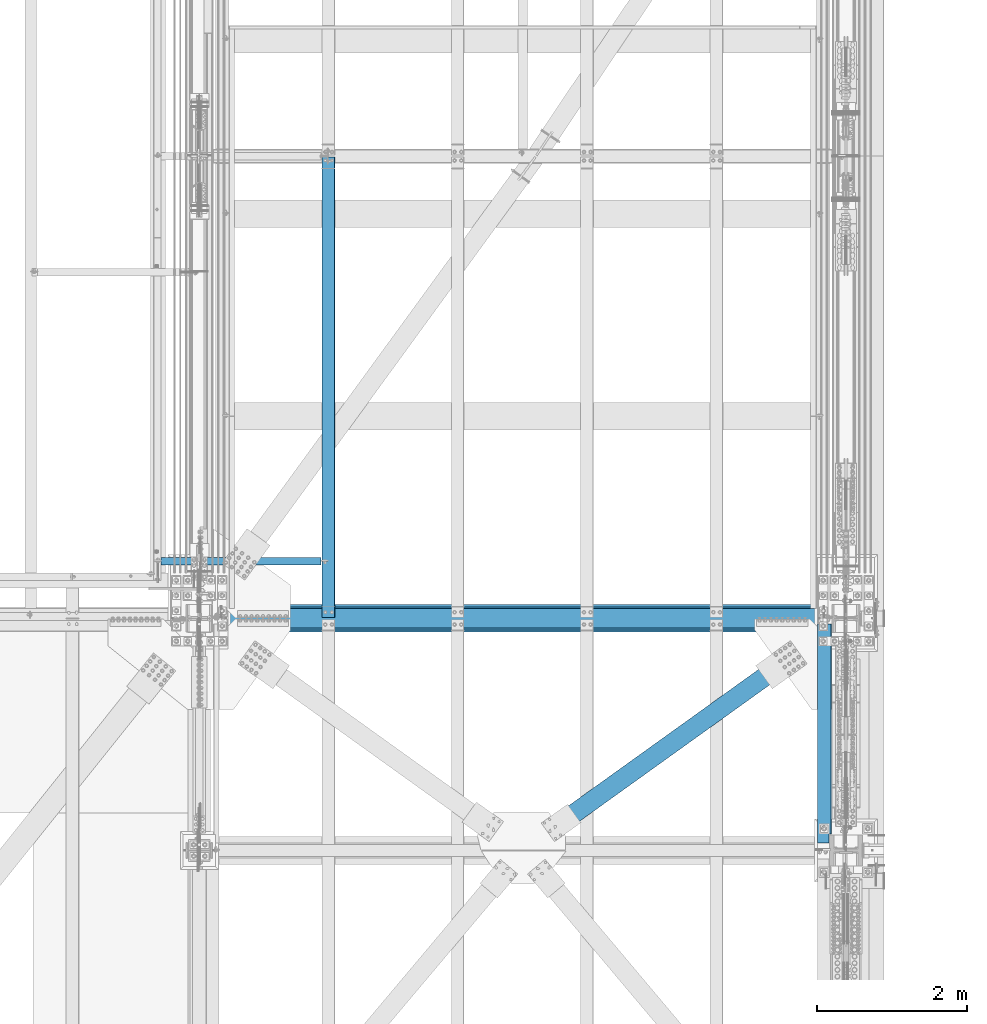
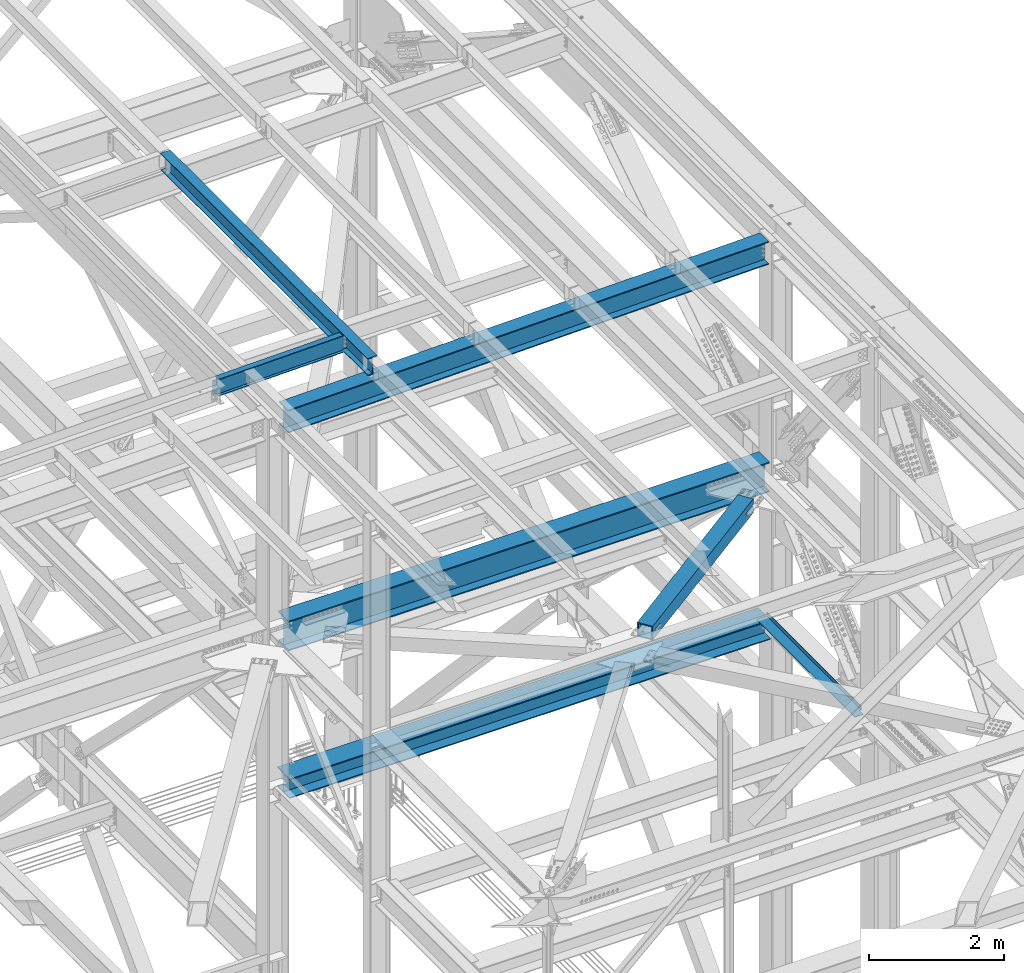
# One storey, part 1988 of 3843: 7 beams, 7 elements without a shape of their own.
"""IFC2X3 building model written with IfcOpenShell, lengths in millimetres."""

import ifcopenshell
import ifcopenshell.guid

model = None  # the IFC model being written
_history = None  # IfcOwnerHistory: only IFC2X3 demands one
_inside = {}  # id of a spatial element -> (the spatial element, [elements in it])
_under = {}  # id of a project, library or spatial element -> (it, [spatial elements below it])
_declared = {}  # id of a project -> (the project, [libraries it declares])
_typed = {}  # id of a type object -> (the type object, [elements of that type])
_made_of = {}  # id of a material, layer set ... -> (it, [elements and type objects made of it])


def new_model(schema):
    """Start an empty IFC model of exactly this schema.

    Asked for "IFC4X3", IfcOpenShell would pick the latest addendum, in which some entities
    have other attributes; the version numbers below select the first issue.
    IFC2X3 requires an IfcOwnerHistory on every rooted entity: one is made here for all.
    """
    global model, _history
    if schema == "IFC4X3":
        model = ifcopenshell.file(schema_version=(4, 3, 0, 0))
    else:
        model = ifcopenshell.file(schema=schema)
    _inside.clear()
    _under.clear()
    _declared.clear()
    _typed.clear()
    _made_of.clear()
    _history = None
    if model.schema == "IFC2X3":
        org = make("IfcOrganization", Name="unknown")
        user = make(
            "IfcPersonAndOrganization",
            ThePerson=make("IfcPerson", FamilyName="unknown"),
            TheOrganization=org,
        )
        app = make(
            "IfcApplication",
            ApplicationDeveloper=org,
            Version="unknown",
            ApplicationFullName="unknown",
            ApplicationIdentifier="unknown",
        )
        _history = make(
            "IfcOwnerHistory",
            OwningUser=user,
            OwningApplication=app,
            ChangeAction="ADDED",
            CreationDate=0,
        )
    return model


def make(cls, **values):
    """One entity of the class cls with the attributes given. An attribute that is None is left unset."""
    return model.create_entity(
        cls, **{name: value for name, value in values.items() if value is not None}
    )


def rooted(cls, **values):
    """An entity with a GlobalId (a new one), such as an element, a storey or a relation."""
    return make(cls, GlobalId=ifcopenshell.guid.new(), OwnerHistory=_history, **values)


def si_unit(unit_type, name, prefix=None):
    """IfcSIUnit, for example si_unit("LENGTHUNIT", "METRE", prefix="MILLI")."""
    return make("IfcSIUnit", UnitType=unit_type, Prefix=prefix, Name=name)


def assignment(units):
    """IfcUnitAssignment: the units of a project."""
    return None if units is None else make("IfcUnitAssignment", Units=units)


def point(xyz):
    """IfcCartesianPoint."""
    return None if xyz is None else make("IfcCartesianPoint", Coordinates=xyz)


def direction(xyz):
    """IfcDirection."""
    return None if xyz is None else make("IfcDirection", DirectionRatios=xyz)


def frame(location, z_axis=None, x_axis=None):
    """IfcAxis2Placement3D, a coordinate frame: its origin and axes. An axis left out is left unset."""
    return make(
        "IfcAxis2Placement3D",
        Location=point(location),
        Axis=direction(z_axis),
        RefDirection=direction(x_axis),
    )


def origin_with_axes():
    """The frame at (0, 0, 0) with the z axis (0, 0, 1) and the x axis (1, 0, 0) written out."""
    return frame((0.0, 0.0, 0.0), z_axis=(0.0, 0.0, 1.0), x_axis=(1.0, 0.0, 0.0))


def place(relative_to, where):
    """IfcLocalPlacement: puts the frame where relative to a parent placement (None: the world)."""
    return make(
        "IfcLocalPlacement", PlacementRelTo=relative_to, RelativePlacement=where
    )


def context(
    kind, dimensions, precision=None, world=None, true_north=None, identifier=None
):
    """IfcGeometricRepresentationContext, for example the 3D "Model" context."""
    return make(
        "IfcGeometricRepresentationContext",
        ContextIdentifier=identifier,
        ContextType=kind,
        CoordinateSpaceDimension=dimensions,
        Precision=precision,
        WorldCoordinateSystem=world,
        TrueNorth=true_north,
    )


def subcontext(parent, identifier, kind, view, scale=None):
    """IfcGeometricRepresentationSubContext, for example "Body" below "Model"."""
    return make(
        "IfcGeometricRepresentationSubContext",
        ContextIdentifier=identifier,
        ContextType=kind,
        ParentContext=parent,
        TargetScale=scale,
        TargetView=view,
    )


def project(units=None, contexts=None):
    """IfcProject with its units and contexts."""
    return rooted(
        "IfcProject",
        Name="project",
        RepresentationContexts=contexts,
        UnitsInContext=assignment(units),
    )


def spatial(cls, under=None, at=None, **own):
    """A site, building, storey or space (cls), placed at a placement, below another one or the project."""
    s = rooted(cls, ObjectPlacement=at, **own)
    if under is not None:
        _under.setdefault(under.id(), (under, []))[1].append(s)
    return s


def faces_of(points, faces, orient=None, outer=None):
    """IfcFace entities. A face is a list of loops; a loop is a list of indices into points, from 0.

    orient and outer hold one flag for each loop. By default every Orientation is true, the
    first loop of a face is its IfcFaceOuterBound and the others are IfcFaceBound.
    """
    made = []
    for i, loops in enumerate(faces):
        bounds = []
        for j, loop in enumerate(loops):
            is_outer = j == 0 if outer is None else outer[i][j]
            bounds.append(
                make(
                    "IfcFaceOuterBound" if is_outer else "IfcFaceBound",
                    Bound=make("IfcPolyLoop", Polygon=[points[k] for k in loop]),
                    Orientation=True if orient is None else orient[i][j],
                )
            )
        made.append(make("IfcFace", Bounds=bounds))
    return made


def faceted_brep(points, faces, orient=None, outer=None, voids=None):
    """IfcFacetedBrep: a solid bounded by flat faces; with voids (closed shells), ...WithVoids."""
    shared = [point(p) for p in points]
    hull = make("IfcClosedShell", CfsFaces=faces_of(shared, faces, orient, outer))
    if voids is None:
        return make("IfcFacetedBrep", Outer=hull)
    return make(
        "IfcFacetedBrepWithVoids",
        Outer=hull,
        Voids=[
            make(cls, CfsFaces=faces_of(shared, fs, o, b)) for cls, fs, o, b in voids
        ],
    )


def shape(context_of_items, identifier, shape_type, items):
    """IfcShapeRepresentation: the items that make up one representation, for example the "Body"."""
    return make(
        "IfcShapeRepresentation",
        ContextOfItems=context_of_items,
        RepresentationIdentifier=identifier,
        RepresentationType=shape_type,
        Items=items,
    )


def material(Name=None, Category=None):
    """IfcMaterial."""
    return make("IfcMaterial", Name=Name, Category=Category)


def made_of(thing, what):
    """Note that an element or type object is made of a material, layer set ...; save() writes the relation."""
    if what is not None:
        _made_of.setdefault(what.id(), (what, []))[1].append(thing)
    return thing


def type_object(cls, material=None, **own):
    """A type object (cls), such as IfcWallType, which elements share."""
    return made_of(rooted(cls, **own), material)


def element(
    cls,
    number,
    at=None,
    inside=None,
    cuts=None,
    type_object=None,
    material=None,
    context=None,
    identifier="Body",
    shape_type=None,
    held_by="IfcProductDefinitionShape",
    body=None,
    shapes=None,
    **own,
):
    """One element of the class cls, such as IfcWall. Its Tag is "e" and its number.

    at: its placement. inside: the storey or other place that contains it. cuts: it is an
    opening in that element (IfcRelVoidsElement). A single representation is given by context,
    identifier, shape_type and body (its items); several are given by shapes. held_by: the class
    of the entity that holds the representations. save() writes the other relations.
    """
    e = rooted(cls, Tag="e%d" % number, ObjectPlacement=at, **own)
    if body is not None:
        shapes = [shape(context, identifier, shape_type, body)]
    if shapes is not None:
        e.Representation = make(held_by, Representations=shapes)
    if inside is not None:
        _inside.setdefault(inside.id(), (inside, []))[1].append(e)
    if cuts is not None:
        rooted(
            "IfcRelVoidsElement", RelatingBuildingElement=cuts, RelatedOpeningElement=e
        )
    if type_object is not None:
        _typed.setdefault(type_object.id(), (type_object, []))[1].append(e)
    return made_of(e, material)


def aggregate(whole, parts):
    """IfcRelAggregates: a whole, such as a stair, and the parts it consists of."""
    return rooted("IfcRelAggregates", RelatingObject=whole, RelatedObjects=parts)


def save(model, path):
    """Write the relations noted so far, then the file.

    IfcRelAggregates (storeys below a building ...), IfcRelContainedInSpatialStructure (elements
    in a storey), IfcRelDefinesByType, IfcRelAssociatesMaterial and IfcRelDeclares: one each for
    every whole, place, type object, material and project.
    """
    for whole, parts in _under.values():
        aggregate(whole, parts)
    for where, things in _inside.values():
        rooted(
            "IfcRelContainedInSpatialStructure",
            RelatedElements=things,
            RelatingStructure=where,
        )
    for kind, things in _typed.values():
        rooted("IfcRelDefinesByType", RelatedObjects=things, RelatingType=kind)
    for what, things in _made_of.values():
        rooted("IfcRelAssociatesMaterial", RelatedObjects=things, RelatingMaterial=what)
    for by, libraries in _declared.values():
        rooted("IfcRelDeclares", RelatingContext=by, RelatedDefinitions=libraries)
    model.write(path)


model = new_model("IFC2X3")

# Units and contexts
model_context = context("Model", 3, precision=1e-05, world=origin_with_axes())
body_context = subcontext(model_context, "Body", "Model", "MODEL_VIEW")
ifc_project = project(units=[si_unit("LENGTHUNIT", "METRE", prefix="MILLI"), si_unit("AREAUNIT", "SQUARE_METRE"), si_unit("VOLUMEUNIT", "CUBIC_METRE"), si_unit("MASSUNIT", "GRAM", prefix="KILO"), si_unit("TIMEUNIT", "SECOND"), si_unit("PLANEANGLEUNIT", "RADIAN"), si_unit("SOLIDANGLEUNIT", "STERADIAN"), si_unit("THERMODYNAMICTEMPERATUREUNIT", "DEGREE_CELSIUS"), si_unit("LUMINOUSINTENSITYUNIT", "LUMEN")], contexts=[model_context])

# Site, building, storey
site_placement = place(None, origin_with_axes())
site = spatial("IfcSite", under=ifc_project, at=site_placement, CompositionType="ELEMENT")
building_placement = place(site_placement, origin_with_axes())
building = spatial("IfcBuilding", under=site, at=building_placement, Name="Undefined", CompositionType="ELEMENT")
storey_placement = place(building_placement, origin_with_axes())
storey = spatial("IfcBuildingStorey", under=building, at=storey_placement, Name="Undefined", CompositionType="ELEMENT", Elevation=0.0)

# Assembly, beam
assembly_1_placement = place(storey_placement, origin_with_axes())
assembly_1 = element("IfcElementAssembly", 1, at=assembly_1_placement, inside=storey, Name="BEAM", AssemblyPlace="NOTDEFINED", PredefinedType="RIGID_FRAME")
ifc_material_1 = material(Name="STEEL/A992")
beam_type_1 = type_object("IfcBeamType", Name="W12X26", PredefinedType="NOTDEFINED")
beam_1_placement = place(assembly_1_placement, frame((78736.7092624381, 92214.7, 46465.9718519106), z_axis=(-0.0211520980073474, 0.0, 0.999776269347241), x_axis=(0.0, 1.0, 0.0)))
beam_1 = element("IfcBeam", 2, at=beam_1_placement, type_object=beam_type_1, material=ifc_material_1, Name="BEAM", ObjectType="W12X26", context=body_context, shape_type="Brep", body=[
    faceted_brep([(12.7000000064072, 82.5500000002939, -155.574999999815), (12.7000000064072, 82.5500000003085, -146.049999999828), (6159.50000000003, 82.5500000003085, -146.049999999836), (6159.50000000003, 82.5500000003085, -155.574999999822), (12.7000000064072, 3.17499999985739, -146.049999999763), (6159.50000000003, 3.17499999985739, -146.049999999777), (12.7000000064072, 3.17500000014843, 146.04999999977), (6159.50000000003, 3.17500000014843, 146.049999999763), (12.7000000064072, 82.5500000005995, 146.049999999697), (6159.50000000003, 82.5500000005995, 146.049999999697), (12.7000000064072, 82.5500000006141, 155.574999999684), (6159.50000000003, 82.5500000005995, 155.574999999677), (12.7000000064072, -82.5500000003231, 155.574999999822), (6159.50000000003, -82.5500000003231, 155.574999999822), (12.7000000064072, -82.5500000003231, 146.049999999836), (6159.50000000003, -82.5500000003231, 146.049999999828), (12.7000000064072, -3.17499999987194, 146.049999999777), (6159.50000000003, -3.17499999987194, 146.049999999763), (12.7000000064072, -3.17500000016298, -146.049999999763), (6159.50000000003, -3.17500000017753, -146.049999999763), (12.7000000064072, -82.5500000006141, -146.04999999969), (6159.50000000003, -82.5500000006286, -146.049999999697), (12.7000000064072, -82.5500000006432, -155.574999999677), (6159.50000000003, -82.5500000006286, -155.574999999677)], [[[0, 1, 2, 3]], [[1, 4, 5, 2]], [[4, 6, 7, 5]], [[6, 8, 9, 7]], [[8, 10, 11, 9]], [[10, 12, 13, 11]], [[12, 14, 15, 13]], [[14, 16, 17, 15]], [[16, 18, 19, 17]], [[18, 20, 21, 19]], [[20, 22, 23, 21]], [[22, 0, 3, 23]], [[5, 7, 9, 11, 13, 15, 17, 19, 21, 23, 3, 2]], [[22, 20, 18, 16, 14, 12, 10, 8, 6, 4, 1, 0]]]),
])
aggregate(assembly_1, [beam_1])

assembly_2_placement = place(storey_placement, origin_with_axes())
assembly_2 = element("IfcElementAssembly", 3, at=assembly_2_placement, inside=storey, Name="BEAM", AssemblyPlace="NOTDEFINED", PredefinedType="RIGID_FRAME")
beam_type_2 = type_object("IfcBeamType", Name="W21X101", PredefinedType="NOTDEFINED")
beam_2_placement = place(assembly_2_placement, frame((77012.8000005026, 92214.7, 42197.3375), z_axis=(0.0, 0.0, 1.0), x_axis=(1.0, 0.0, 0.0)))
beam_2 = element("IfcBeam", 4, at=beam_2_placement, type_object=beam_type_2, material=ifc_material_1, Name="BEAM", ObjectType="W21X101", context=body_context, shape_type="Brep", body=[
    faceted_brep([(190.5, -155.575000000001, -271.462500000001), (190.5, 155.575000000001, -271.462500000001), (8439.15000000001, 155.575000000001, -271.462500000001), (8439.15000000001, -155.575000000001, -271.462500000001), (190.5, -155.575000000001, -250.824999999997), (190.5, -6.34999999999854, -250.824999999997), (190.5, -6.34999999999854, 250.824999999997), (190.5, -155.575000000001, 250.824999999997), (190.5, -155.575000000001, 271.462500000001), (190.5, 155.575000000001, 271.462500000001), (190.5, 155.575000000001, 250.824999999997), (190.5, 6.34999999999854, 250.824999999997), (190.5, 6.35000000000582, 214.312499999993), (190.5, 6.35000000000582, -181.387500000004), (190.5, 6.34999999999854, -250.824999999997), (190.5, 155.575000000001, -250.824999999997), (8439.15000000001, -155.575000000001, -250.824999999997), (8439.15000000001, -6.34999999999854, -250.824999999997), (8439.15000000001, -6.34999999999854, 250.824999999997), (8439.15000000001, -155.575000000001, 250.824999999997), (8439.15000000001, -155.575000000001, 271.462500000001), (8439.15000000001, 155.575000000001, 271.462500000001), (8439.15000000001, 155.575000000001, 250.824999999997), (8439.15000000001, 6.34999999999854, 250.824999999997), (8439.15000000001, 6.34999999999854, 207.962500000001), (8439.15000000001, 6.34999999999854, -175.037499999999), (8439.15000000001, 6.34999999999854, -250.824999999997), (8439.15000000001, 155.575000000001, -250.824999999997)], [[[0, 1, 2, 3]], [[0, 4, 5, 6, 7, 8, 9, 10, 11, 12, 13, 14, 15, 1]], [[5, 4, 16, 17]], [[6, 5, 17, 18]], [[7, 6, 18, 19]], [[8, 7, 19, 20]], [[9, 8, 20, 21]], [[10, 9, 21, 22]], [[11, 10, 22, 23]], [[14, 13, 12, 11, 23, 24, 25, 26]], [[15, 14, 26, 27]], [[1, 15, 27, 2]], [[26, 25, 24, 23, 22, 21, 20, 19, 18, 17, 16, 3, 2, 27]], [[4, 0, 3, 16]]]),
])
aggregate(assembly_2, [beam_2])

assembly_3_placement = place(storey_placement, origin_with_axes())
assembly_3 = element("IfcElementAssembly", 5, at=assembly_3_placement, inside=storey, Name="BEAM", AssemblyPlace="NOTDEFINED", PredefinedType="RIGID_FRAME")
beam_type_3 = type_object("IfcBeamType", Name="W12X19", PredefinedType="NOTDEFINED")
beam_3_placement = place(assembly_3_placement, frame((76406.4571598578, 92976.7, 46418.2589406468), z_axis=(-0.0211520980073474, 0.0, 0.999776269347241), x_axis=(0.999776270257024, 0.0, 0.0211520550054619)))
beam_3 = element("IfcBeam", 6, at=beam_3_placement, type_object=beam_type_3, material=ifc_material_1, Name="BEAM", ObjectType="W12X19", context=body_context, shape_type="Brep", body=[
    faceted_brep([(2232.3149825334, -3.17500000000291, -144.462499991867), (2232.3149825334, -50.8000000000029, -144.462499991867), (2232.31498253353, -50.8000000000029, -153.987499991876), (2232.31498253353, 50.8000000000029, -153.987499991876), (2232.3149825334, 50.8000000000029, -144.462499991867), (2232.3149825334, 3.17500000000291, -144.462499991867), (2232.31498253338, 3.17500000000291, -141.287499725579), (2232.31498253338, -3.17500000000291, -141.287499725579), (2233.28171245592, 3.17500000000291, -136.427420207467), (2233.28171245592, -3.17500000000291, -136.427420207467), (2236.03472635635, 3.17500000000291, -132.307243739255), (2236.03472635635, -3.17500000000291, -132.307243739255), (2240.15490282445, 3.17500000000291, -129.554229838737), (2240.15490282445, -3.17500000000291, -129.554229838737), (2245.01498234246, 3.17500000000291, -128.587499916146), (2245.01498234246, -3.17500000000291, -128.587499916146), (2314.86498100203, -3.17500000000291, -128.587499916357), (2314.86498100203, 3.17500000000291, -128.587499916357), (96.8374980314547, 3.17500000000291, 144.462500000489), (96.8374980314547, 50.8000000000029, 144.462500000489), (2232.31498253648, 50.8000000000029, 144.462500008405), (2232.31498253648, 3.17500000000291, 144.462500008405), (96.8374977455387, -3.17500000000291, -141.287499907492), (96.8374977455387, 3.17500000000291, -141.287499907492), (96.8374977423518, 3.17500000000291, -144.462499999776), (96.8374977423518, 50.8000000000029, -144.462499999776), (96.8374977328203, 50.8000000000029, -153.987499999792), (96.8374977328203, -50.8000000000029, -153.987499999792), (96.8374977423518, -50.8000000000029, -144.462499999776), (96.8374977423518, -3.17500000000291, -144.462499999776), (95.8707678278151, -3.17500000000291, -136.427420388471), (95.8707678278151, 3.17500000000291, -136.427420388471), (93.1177539315104, -3.17500000000291, -132.307243917545), (93.1177539315104, 3.17500000000291, -132.307243917545), (88.9975774661289, -3.17500000000291, -129.554230012938), (88.9975774661289, 3.17500000000291, -129.554230012938), (84.1374979491229, -3.17500000000291, -128.587500085479), (84.1374979491229, 3.17500000000291, -128.587500085479), (20.6374979119428, -3.17500000000291, -128.587500021946), (20.6374979119428, 3.17500000000291, -128.587500021946), (20.637499711811, -3.17500000000291, 128.587499979069), (20.637499711811, 3.17500000000291, 128.587499979069), (20.6374996229279, 3.17500000000291, 115.88750024372), (20.6374980090477, 3.17500000000291, -114.712499752241), (84.1374982064444, -3.17500000000291, 128.587499915513), (84.1374982064444, 3.17500000000291, 128.587499915513), (88.9975777254003, -3.17500000000291, 129.554229833244), (88.9975777254003, 3.17500000000291, 129.554229833244), (93.1177541962679, -3.17500000000291, 132.307243729607), (93.1177541962679, 3.17500000000291, 132.307243729607), (95.8707681008382, -3.17500000000291, 136.427420195025), (95.8707681008382, 3.17500000000291, 136.427420195025), (96.8374980282824, -3.17500000000291, 141.287499712118), (96.8374980282824, 3.17500000000291, 141.287499712118), (96.8374980410154, -50.8000000000029, 153.987499285155), (96.8374980410008, 50.8000000000029, 153.987500000498), (96.8374980314547, -3.17500000000291, 144.462500000489), (96.8374980314547, -50.8000000000029, 144.462500000489), (2232.31498253648, -3.17500000000291, 144.462500008405), (2232.31498253648, -50.8000000000029, 144.462500008405), (2232.31498253638, -50.8000000000029, 153.987499981791), (2232.31498253639, 50.8000000000029, 153.987500008421), (2232.31498253651, -3.17500000000291, 141.28749989366), (2232.31498253651, 3.17500000000291, 141.28749989366), (2233.28171245912, -3.17500000000291, 136.427420375658), (2233.28171245912, 3.17500000000291, 136.427420375658), (2236.03472635955, -3.17500000000291, 132.30724390754), (2236.03472635955, 3.17500000000291, 132.30724390754), (2240.15490282758, -3.17500000000291, 129.554230007096), (2240.15490282758, 3.17500000000291, 129.554230007096), (2245.0149823455, -3.17500000000291, 128.587500084504), (2245.0149823455, 3.17500000000291, 128.587500084504), (2314.86498280188, -3.17500000000291, 128.58750008425), (2314.86498280188, 3.17500000000291, 128.58750008425), (2314.86498109912, 3.17500000000291, -114.712500309615), (2314.864982713, 3.17500000000291, 115.887499687808)], [[[0, 1, 2, 3, 4, 5, 6, 7]], [[7, 6, 8, 9]], [[9, 8, 10, 11]], [[11, 10, 12, 13]], [[13, 12, 14, 15]], [[16, 15, 14, 17]], [[18, 19, 20, 21]], [[22, 23, 24, 25, 26, 27, 28, 29]], [[30, 31, 23, 22]], [[32, 33, 31, 30]], [[34, 35, 33, 32]], [[36, 37, 35, 34]], [[38, 39, 37, 36]], [[40, 41, 42, 43, 39, 38]], [[44, 45, 41, 40]], [[46, 47, 45, 44]], [[48, 49, 47, 46]], [[50, 51, 49, 48]], [[52, 53, 51, 50]], [[54, 55, 19, 18, 53, 52, 56, 57]], [[57, 56, 58, 59]], [[54, 57, 59, 60]], [[55, 54, 60, 61]], [[19, 55, 61, 20]], [[60, 59, 58, 62, 63, 21, 20, 61]], [[64, 65, 63, 62]], [[66, 67, 65, 64]], [[68, 69, 67, 66]], [[70, 71, 69, 68]], [[72, 73, 71, 70]], [[74, 75, 73, 72, 16, 17]], [[12, 10, 8, 6, 5, 24, 23, 31, 33, 35, 37, 39, 43, 42, 41, 45, 47, 49, 51, 53, 18, 21, 63, 65, 67, 69, 71, 73, 75, 74, 17, 14]], [[25, 24, 5, 4]], [[26, 25, 4, 3]], [[27, 26, 3, 2]], [[28, 27, 2, 1]], [[29, 28, 1, 0]], [[72, 70, 68, 66, 64, 62, 58, 56, 52, 50, 48, 46, 44, 40, 38, 36, 34, 32, 30, 22, 29, 0, 7, 9, 11, 13, 15, 16]]]),
])
aggregate(assembly_3, [beam_3])

assembly_4_placement = place(storey_placement, origin_with_axes())
assembly_4 = element("IfcElementAssembly", 7, at=assembly_4_placement, inside=storey, Name="BENT_PLATE", AssemblyPlace="NOTDEFINED", PredefinedType="RIGID_FRAME")
ifc_material_2 = material(Name="STEEL/A36")
beam_type_4 = type_object("IfcBeamType", PredefinedType="NOTDEFINED")
beam_4_placement = place(assembly_4_placement, frame((85269.3874999998, 90678.0, 39627.1750000002), z_axis=(0.0, 1.0, 0.0), x_axis=(1.0, 0.0, 0.0)))
beam_4 = element("IfcBeam", 8, at=beam_4_placement, type_object=beam_type_4, material=ifc_material_2, Name="BENT_PLATE", context=body_context, shape_type="Brep", body=[
    faceted_brep([(149.22500000021, -3.17500000000291, -1460.5), (149.22500000021, 3.17500000000291, -1460.5), (149.225000000151, 3.17500000000291, -1343.02499999999), (149.225000000151, -3.17500000000291, -1343.02499999999), (182.562500000131, -73.0250000001033, -1343.02500000002), (176.212500000212, -73.0250000001179, -1343.02500000002), (176.21250000014, -3.17500000000291, -1343.02500000002), (182.562500000131, 3.17500000000291, -1343.02500000002), (0.0, -3.17500000000291, -1460.5), (0.0, -3.17500000000291, 1460.5), (0.0, 3.17500000000291, 1460.5), (0.0, 3.17500000000291, -1460.5), (182.562500000131, 3.17500000000291, 1460.5), (176.21250000014, -3.17500000000291, 1460.5), (176.212500000212, -73.0250000001179, 1460.5), (182.562500000218, -73.0250000001033, 1460.5)], [[[0, 1, 2, 3]], [[4, 5, 6, 3, 2, 7]], [[8, 9, 10, 11]], [[12, 10, 9, 13, 14, 15]], [[12, 15, 4, 7]], [[1, 11, 10, 12, 7, 2]], [[8, 11, 1, 0]], [[13, 9, 8, 0, 3, 6]], [[14, 13, 6, 5]], [[15, 14, 5, 4]]]),
])
aggregate(assembly_4, [beam_4])

assembly_5_placement = place(storey_placement, origin_with_axes())
assembly_5 = element("IfcElementAssembly", 9, at=assembly_5_placement, inside=storey, AssemblyPlace="NOTDEFINED", PredefinedType="RIGID_FRAME")
ifc_material_3 = material()
beam_type_5 = type_object("IfcBeamType", Name="HSS10X10X3/4", PredefinedType="NOTDEFINED")
beam_5_placement = place(assembly_5_placement, frame((81330.800000019, 89115.8999996223, 42246.55), z_axis=(0.583045050783809, -0.812439824698731, 0.0), x_axis=(0.812439824698741, 0.583045050783796, 0.0)))
beam_5 = element("IfcBeam", 10, at=beam_5_placement, type_object=beam_type_5, material=ifc_material_3, ObjectType="HSS10X10X3/4", context=body_context, shape_type="Brep", body=[
    faceted_brep([(832.719832391842, 14.2874999999767, 127.000000005144), (832.719832391958, 14.2874999999767, 107.950000005156), (845.419832392203, 14.2874999999767, 107.950000005243), (845.419832392086, 14.2874999999767, 127.000000005246), (848.457382136592, 13.6832937892832, 107.950000005258), (848.457382136476, 13.6832937892832, 127.000000005246), (851.032492467857, 11.9626600756455, 107.950000005279), (851.032492467741, 11.9626600756455, 127.000000005268), (852.753126181502, 9.38754974437325, 107.950000005294), (852.753126181371, 9.38754974437325, 127.000000005268), (845.419832392086, -1.58750000002328, 127.000000005246), (845.419832392203, -1.58750000002328, 107.950000005243), (832.719832391958, -1.58750000002328, 107.950000005156), (832.719832391842, -1.58750000002328, 127.000000005144), (848.457382136476, -0.983293789329764, 127.000000005246), (848.457382136592, -0.983293789329764, 107.950000005258), (851.032492467741, 0.737339924307889, 127.000000005268), (851.032492467857, 0.737339924307889, 107.950000005279), (852.753126181371, 3.31245025558019, 127.000000005268), (852.753126181502, 3.31245025558019, 107.950000005294), (853.357332392057, 6.34999999997672, 127.000000005282), (853.357332392188, 6.34999999997672, 107.950000005301), (832.719832393312, 14.2874999999767, -107.949999994686), (832.719832393428, 14.2874999999767, -126.999999994681), (845.419832393673, 14.2874999999767, -126.999999994601), (845.419832393556, 14.2874999999767, -107.949999994613), (848.457382138062, 13.6832937892832, -126.999999994579), (848.457382137945, 13.6832937892832, -107.949999994591), (851.032492469327, 11.9626600756455, -126.999999994565), (851.032492469225, 11.9626600756455, -107.949999994569), (852.753126182957, 9.38754974437325, -126.999999994565), (852.753126182841, 9.38754974437325, -107.949999994577), (845.419832393556, -1.58750000002328, -107.949999994613), (845.419832393673, -1.58750000002328, -126.999999994601), (832.719832393428, -1.58750000002328, -126.999999994681), (832.719832393312, -1.58750000002328, -107.949999994686), (848.457382137945, -0.983293789329764, -107.949999994591), (848.457382138062, -0.983293789329764, -126.999999994579), (851.032492469225, 0.737339924307889, -107.949999994569), (851.032492469327, 0.737339924307889, -126.999999994565), (852.753126182841, 3.31245025558019, -107.949999994577), (852.753126182957, 3.31245025558019, -126.999999994565), (853.357332393542, 6.34999999997672, -107.949999994555), (853.357332393658, 6.34999999997672, -126.999999994558), (593.007332395049, 127.0, -126.999999996173), (593.007332395049, 127.0, 127.000000003653), (4220.92128598434, 127.0, 127.000000005952), (4220.92128598454, 127.0, -126.999999993059), (593.007332395049, -127.0, 127.000000003653), (593.007332395049, -127.0, -126.999999996173), (4220.92128598454, -127.0, -126.999999993059), (4220.92128598434, -127.0, 127.000000005952), (4220.92128635551, 26.9874999999884, -107.949999973403), (3968.50878673453, 26.9874999999884, -107.949999974982), (3968.50878673464, 26.9874999999884, -126.999999974956), (4220.92128635551, 26.9874999999884, -126.999999973392), (3963.04119704863, 25.8999287917031, -107.949999975026), (3963.04119704876, 25.8999287917031, -126.999999975014), (3958.40599832861, 22.8027880244626, -107.949999975041), (3958.40599832873, 22.8027880244626, -126.999999975029), (3955.30885756137, 18.1675893044157, -107.949999975062), (3955.30885756148, 18.1675893044157, -126.999999975043), (3954.22128635309, 12.6999996185186, -107.94999997507), (3954.2212863532, 12.6999996185186, -126.999999975058), (3955.30885756137, 7.23241069556389, -107.949999975062), (3955.30885756148, 7.23241069556389, -126.999999975043), (3958.40599832861, 2.59721197551698, -107.949999975041), (3958.40599832873, 2.59721197551698, -126.999999975029), (3963.04119704863, -0.499928791723505, -107.949999975026), (3963.04119704876, -0.499928791723505, -126.999999975014), (3968.50878673453, -1.58750000000873, -107.949999974982), (3968.50878673464, -1.58750000000873, -126.999999974956), (4220.92128635551, -1.58750000000873, -107.949999973403), (4220.92128635551, -1.58750000000873, -126.999999973392), (593.007332395049, -107.949999999997, -107.949999996206), (593.007332395049, -107.949999999997, 107.950000003664), (4220.92128598435, -107.949999999997, 107.950000006022), (4220.92128598453, -107.949999999997, -107.949999993143), (4220.92128635551, -1.58750000000873, 107.950000026452), (4220.92128635551, -1.58750000000873, 127.000000026455), (3968.50878673317, -1.58750000000873, 107.950000024874), (3968.50878673304, -1.58750000000873, 127.000000024869), (3963.04119704729, -0.499928791723505, 107.950000024844), (3963.04119704718, -0.499928791723505, 127.000000024818), (3958.40599832726, 2.59721197551698, 107.950000024815), (3958.40599832711, 2.59721197551698, 127.000000024796), (3955.30885756, 7.23241069556389, 107.950000024801), (3955.30885755988, 7.23241069556389, 127.000000024789), (3954.22128635175, 12.6999996185186, 107.950000024786), (3954.2212863516, 12.6999996185186, 127.000000024775), (3955.30885756, 18.1675893044157, 107.950000024801), (3955.30885755988, 18.1675893044157, 127.000000024789), (3958.40599832726, 22.8027880244626, 107.950000024815), (3958.40599832711, 22.8027880244626, 127.000000024796), (3963.04119704729, 25.8999287917031, 107.950000024844), (3963.04119704718, 25.8999287917031, 127.000000024818), (3968.50878673317, 26.9874999999884, 107.950000024874), (3968.50878673304, 26.9874999999884, 127.000000024869), (4220.92128635551, 26.9874999999884, 127.000000026455), (4220.92128635551, 26.9874999999884, 107.950000026452), (4220.92128598435, 107.949999999997, 107.950000006022), (4220.92128598453, 107.949999999997, -107.949999993143), (593.007332395049, 107.949999999997, 107.950000003664), (593.007332395049, 107.949999999997, -107.949999996206), (593.007332395049, 14.2874999999767, -126.999999996173), (593.007332395049, 14.2874999999767, -107.949999996206), (593.007332395049, 14.2874999999767, 107.950000003664), (593.007332395049, 14.2874999999767, 127.000000003653), (593.007332395049, -1.58750000002328, 127.000000003653), (593.007332395049, -1.58750000002328, 107.950000003664), (593.007332395049, -1.58750000002328, -107.949999996206), (593.007332395049, -1.58750000002328, -126.999999996173)], [[[0, 1, 2, 3]], [[3, 2, 4, 5]], [[5, 4, 6, 7]], [[7, 6, 8, 9]], [[10, 11, 12, 13]], [[14, 15, 11, 10]], [[16, 17, 15, 14]], [[18, 19, 17, 16]], [[20, 21, 19, 18]], [[9, 8, 21, 20]], [[22, 23, 24, 25]], [[25, 24, 26, 27]], [[27, 26, 28, 29]], [[29, 28, 30, 31]], [[32, 33, 34, 35]], [[36, 37, 33, 32]], [[38, 39, 37, 36]], [[40, 41, 39, 38]], [[42, 43, 41, 40]], [[31, 30, 43, 42]], [[44, 45, 46, 47]], [[48, 49, 50, 51]], [[52, 53, 54, 55]], [[56, 57, 54, 53]], [[58, 59, 57, 56]], [[60, 61, 59, 58]], [[62, 63, 61, 60]], [[64, 65, 63, 62]], [[66, 67, 65, 64]], [[68, 69, 67, 66]], [[70, 71, 69, 68]], [[72, 73, 71, 70]], [[74, 75, 76, 77]], [[51, 50, 73, 72, 77, 76, 78, 79]], [[79, 78, 80, 81]], [[81, 80, 82, 83]], [[83, 82, 84, 85]], [[85, 84, 86, 87]], [[87, 86, 88, 89]], [[89, 88, 90, 91]], [[91, 90, 92, 93]], [[93, 92, 94, 95]], [[95, 94, 96, 97]], [[98, 97, 96, 99]], [[100, 101, 52, 55, 47, 46, 98, 99]], [[102, 103, 101, 100]], [[45, 44, 104, 105, 103, 102, 106, 107]], [[107, 106, 1, 0]], [[16, 14, 10, 13, 108, 48, 51, 79, 81, 83, 85, 87, 89, 91, 93, 95, 97, 98, 46, 45, 107, 0, 3, 5, 7, 9, 20, 18]], [[6, 4, 2, 1, 106, 102, 100, 99, 96, 94, 92, 90, 88, 86, 84, 82, 80, 78, 76, 75, 109, 12, 11, 15, 17, 19, 21, 8]], [[13, 12, 109, 108]], [[75, 74, 110, 111, 49, 48, 108, 109]], [[35, 34, 111, 110]], [[28, 26, 24, 23, 104, 44, 47, 55, 54, 57, 59, 61, 63, 65, 67, 69, 71, 73, 50, 49, 111, 34, 33, 37, 39, 41, 43, 30]], [[105, 104, 23, 22]], [[38, 36, 32, 35, 110, 74, 77, 72, 70, 68, 66, 64, 62, 60, 58, 56, 53, 52, 101, 103, 105, 22, 25, 27, 29, 31, 42, 40]]]),
])
aggregate(assembly_5, [beam_5])

assembly_6_placement = place(storey_placement, origin_with_axes())
assembly_6 = element("IfcElementAssembly", 11, at=assembly_6_placement, inside=storey, Name="BEAM", AssemblyPlace="NOTDEFINED", PredefinedType="RIGID_FRAME")
beam_type_6 = type_object("IfcBeamType", Name="W16X67", PredefinedType="NOTDEFINED")
beam_6_placement = place(assembly_6_placement, frame((77017.1988427395, 92214.7, 46065.9736071237), z_axis=(-0.0211520980073474, 0.0, 0.999776269347241), x_axis=(0.999776270257024, 0.0, 0.0211520550054619)))
beam_6 = element("IfcBeam", 12, at=beam_6_placement, type_object=beam_type_6, material=ifc_material_1, Name="BEAM", ObjectType="W16X67", context=body_context, shape_type="Brep", body=[
    faceted_brep([(181.742975470595, -130.174999999999, -207.962499999499), (181.742975470595, 130.174999999999, -207.962499999499), (8432.23886485929, 130.174999999999, -207.962499992493), (8432.23886485929, -130.174999999999, -207.962499992493), (182.112426639622, -130.174999999999, -190.499999999527), (182.112426639622, -4.76250000000073, -190.499999999527), (190.173179417936, -4.76250000000073, 190.499999999862), (190.173179417936, -130.174999999999, 190.499999999862), (190.542630586948, -130.174999999999, 207.962499999841), (190.542630586948, 130.174999999999, 207.962499999841), (190.173179417936, 130.174999999999, 190.499999999862), (190.173179417936, 4.76250000000073, 190.499999999862), (182.112426639622, 4.76250000000073, -190.499999999527), (182.112426639622, 130.174999999999, -190.499999999527), (8432.60831602832, -130.174999999999, -190.49999999252), (8432.60831602832, -4.76250000000073, -190.49999999252), (8440.66906880663, -4.76250000000073, 190.500000006876), (8440.66906880663, -130.174999999999, 190.500000006876), (8441.03851997564, -130.174999999999, 207.962500006841), (8441.03851997564, 130.174999999999, 207.962500006841), (8440.66906880663, 130.174999999999, 190.500000006876), (8440.66906880663, 4.76250000000073, 190.500000006876), (8432.60831602832, 4.76250000000073, -190.49999999252), (8432.60831602832, 130.174999999999, -190.49999999252)], [[[0, 1, 2, 3]], [[0, 4, 5, 6, 7, 8, 9, 10, 11, 12, 13, 1]], [[5, 4, 14, 15]], [[6, 5, 15, 16]], [[7, 6, 16, 17]], [[8, 7, 17, 18]], [[9, 8, 18, 19]], [[10, 9, 19, 20]], [[11, 10, 20, 21]], [[12, 11, 21, 22]], [[13, 12, 22, 23]], [[1, 13, 23, 2]], [[22, 21, 20, 19, 18, 17, 16, 15, 14, 3, 2, 23]], [[4, 0, 3, 14]]]),
])
aggregate(assembly_6, [beam_6])

assembly_7_placement = place(storey_placement, origin_with_axes())
assembly_7 = element("IfcElementAssembly", 13, at=assembly_7_placement, inside=storey, Name="BEAM", AssemblyPlace="NOTDEFINED", PredefinedType="RIGID_FRAME")
beam_type_7 = type_object("IfcBeamType", Name="W14X90", PredefinedType="NOTDEFINED")
beam_7_placement = place(assembly_7_placement, frame((77012.8, 92214.7, 39446.2), z_axis=(0.0, 0.0, 1.0), x_axis=(1.0, 0.0, 0.0)))
beam_7 = element("IfcBeam", 14, at=beam_7_placement, type_object=beam_type_7, material=ifc_material_1, Name="BEAM", ObjectType="W14X90", context=body_context, shape_type="Brep", body=[
    faceted_brep([(190.499999999985, -184.149999999994, -177.800000000003), (190.499999999985, 184.149999999994, -177.800000000003), (8439.14999999999, 184.149999999994, -177.800000000003), (8439.14999999999, -184.149999999994, -177.800000000003), (190.499999999985, -184.149999999994, -160.337500000001), (190.499999999985, -5.55624999999418, -160.337500000001), (190.499999999985, -5.55624999999418, 160.337500000001), (190.499999999985, -184.149999999994, 160.337500000001), (190.499999999985, -184.149999999994, 177.800000000003), (190.499999999985, 184.149999999994, 177.800000000003), (190.499999999985, 184.149999999994, 160.337500000001), (190.499999999985, 5.55624999999418, 160.337500000001), (190.499999999985, 5.55624999999418, 126.999999999993), (190.499999999985, 5.55624999999418, -103.600000000006), (190.499999999985, 5.55624999999418, -160.337500000001), (190.499999999985, 184.149999999994, -160.337500000001), (8439.14999999999, -184.149999999994, -160.337500000001), (8439.14999999999, -5.55624999999418, -160.337500000001), (8439.14999999999, -5.55624999999418, 160.337500000001), (8439.14999999999, -184.149999999994, 160.337500000001), (8439.14999999999, -184.149999999994, 177.800000000003), (8439.14999999999, 184.149999999994, 177.800000000003), (8439.14999999999, 184.149999999994, 160.337500000001), (8439.14999999999, 5.55624999999418, 160.337500000001), (8439.14999999999, 5.55624999999418, 126.999999999993), (8439.14999999999, 5.55624999999418, -103.600000000006), (8439.14999999999, 5.55624999999418, -160.337500000001), (8439.14999999999, 184.149999999994, -160.337500000001)], [[[0, 1, 2, 3]], [[0, 4, 5, 6, 7, 8, 9, 10, 11, 12, 13, 14, 15, 1]], [[5, 4, 16, 17]], [[6, 5, 17, 18]], [[7, 6, 18, 19]], [[8, 7, 19, 20]], [[9, 8, 20, 21]], [[10, 9, 21, 22]], [[11, 10, 22, 23]], [[14, 13, 12, 11, 23, 24, 25, 26]], [[15, 14, 26, 27]], [[1, 15, 27, 2]], [[26, 25, 24, 23, 22, 21, 20, 19, 18, 17, 16, 3, 2, 27]], [[4, 0, 3, 16]]]),
])
aggregate(assembly_7, [beam_7])

save(model, "model.ifc")
